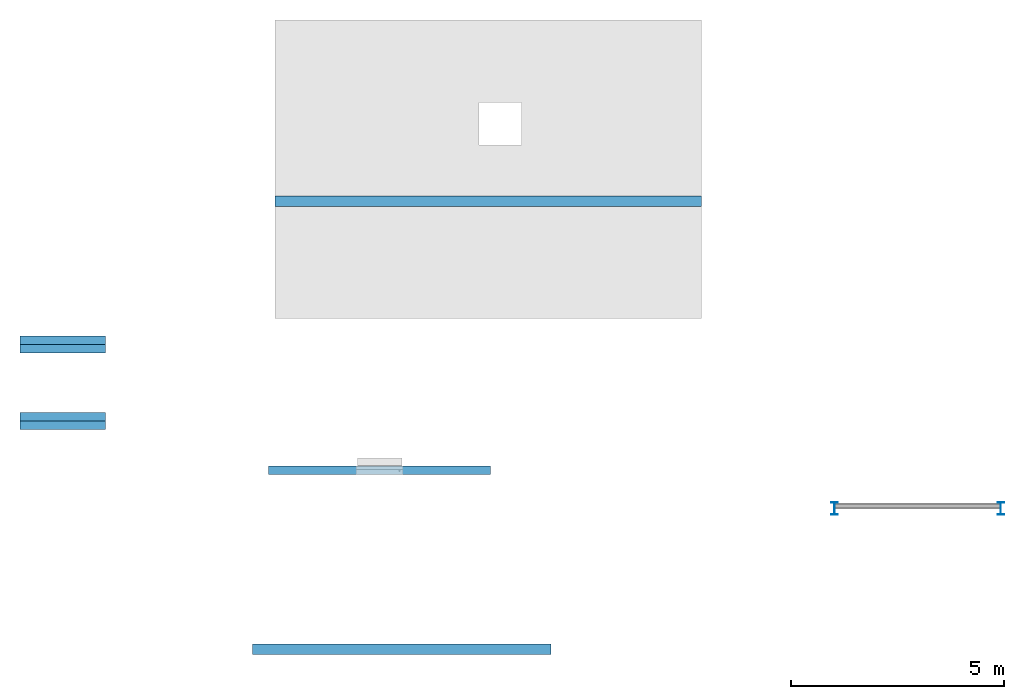
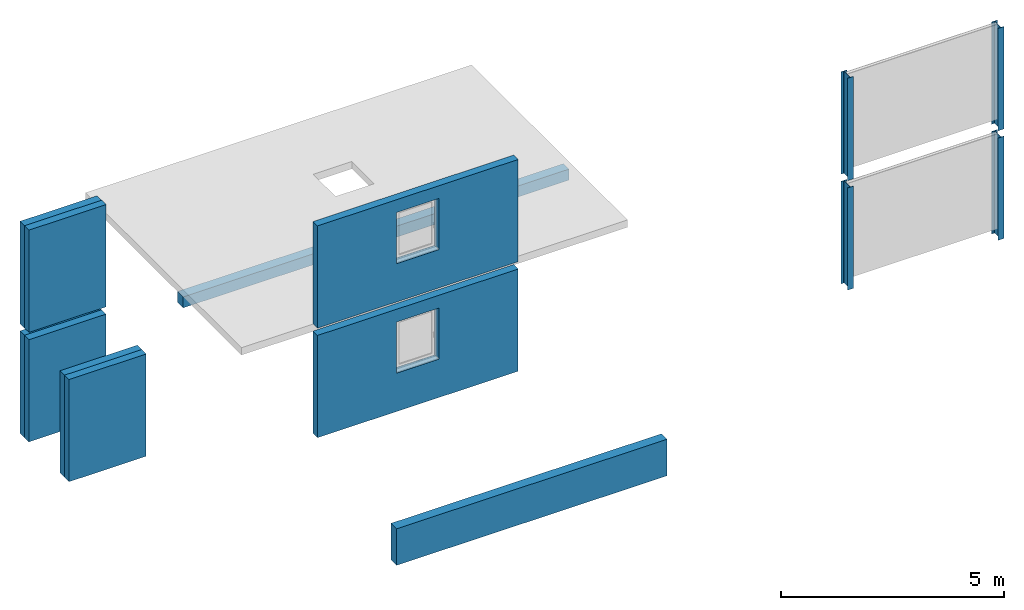
# Not in any storey, part 1 of 3: 8 building element parts, 4 columns, 1 beam, 1 footing, 5 elements without a shape of their own.
"""IFC4 model written with IfcOpenShell, lengths in metres."""

from ifc_helpers import new_model, entity, si_unit, converted_unit, derived_unit, direction, frame, origin, place, context, subcontext, project, spatial, line, arc, indexed_curve, outline, extrude, source, transform, mapped, material, type_object, type_shapes, element, aggregate, save


model = new_model("IFC4")

# Units and contexts
model_context = context("Model", 3, precision=1e-05, world=origin(), true_north=direction((6.123031769111886e-17, 1.0)))
body_context = subcontext(model_context, "Body", "Model", "MODEL_VIEW")
ifc_project = project(units=[si_unit("LENGTHUNIT", "METRE"), si_unit("AREAUNIT", "SQUARE_METRE"), si_unit("VOLUMEUNIT", "CUBIC_METRE"), converted_unit("PLANEANGLEUNIT", "DEGREE", entity("IfcRatioMeasure", 0.017453292519943278), si_unit("PLANEANGLEUNIT", "RADIAN"), dimensions=[0, 0, 0, 0, 0, 0, 0]), si_unit("MASSUNIT", "GRAM", prefix="KILO"), derived_unit("MASSDENSITYUNIT", [(si_unit("MASSUNIT", "GRAM", prefix="KILO"), 1), (si_unit("LENGTHUNIT", "METRE"), -3)]), derived_unit("IONCONCENTRATIONUNIT", [(si_unit("MASSUNIT", "GRAM", prefix="KILO"), 1), (si_unit("LENGTHUNIT", "METRE"), -3)]), derived_unit("MOMENTOFINERTIAUNIT", [(si_unit("LENGTHUNIT", "METRE"), 4)]), si_unit("TIMEUNIT", "SECOND"), si_unit("FREQUENCYUNIT", "HERTZ"), si_unit("THERMODYNAMICTEMPERATUREUNIT", "DEGREE_CELSIUS"), derived_unit("THERMALTRANSMITTANCEUNIT", [(si_unit("MASSUNIT", "GRAM", prefix="KILO"), 1), (si_unit("THERMODYNAMICTEMPERATUREUNIT", "KELVIN"), -1), (si_unit("TIMEUNIT", "SECOND"), -3)]), derived_unit("THERMALCONDUCTANCEUNIT", [(si_unit("MASSUNIT", "GRAM", prefix="KILO"), 1), (si_unit("THERMODYNAMICTEMPERATUREUNIT", "KELVIN"), -1), (si_unit("TIMEUNIT", "SECOND"), -3), (si_unit("LENGTHUNIT", "METRE"), 1)]), derived_unit("VOLUMETRICFLOWRATEUNIT", [(si_unit("LENGTHUNIT", "METRE"), 3), (si_unit("TIMEUNIT", "SECOND"), -1)]), derived_unit("MASSFLOWRATEUNIT", [(si_unit("MASSUNIT", "GRAM", prefix="KILO"), 1), (si_unit("TIMEUNIT", "SECOND"), -1)]), derived_unit("ROTATIONALFREQUENCYUNIT", [(si_unit("TIMEUNIT", "SECOND"), -1)]), si_unit("ELECTRICCURRENTUNIT", "AMPERE"), si_unit("ELECTRICVOLTAGEUNIT", "VOLT"), si_unit("POWERUNIT", "WATT"), si_unit("FORCEUNIT", "NEWTON", prefix="KILO"), si_unit("ILLUMINANCEUNIT", "LUX"), si_unit("LUMINOUSFLUXUNIT", "LUMEN"), si_unit("LUMINOUSINTENSITYUNIT", "CANDELA"), derived_unit("USERDEFINED", [(si_unit("MASSUNIT", "GRAM", prefix="KILO"), -1), (si_unit("LENGTHUNIT", "METRE"), -2), (si_unit("TIMEUNIT", "SECOND"), 3), (si_unit("LUMINOUSFLUXUNIT", "LUMEN"), 1)]), derived_unit("USERDEFINED", [(si_unit("MASSUNIT", "GRAM", prefix="KILO"), 1), (si_unit("TIMEUNIT", "SECOND"), -3), (si_unit("LENGTHUNIT", "METRE"), 3), (si_unit("ELECTRICCURRENTUNIT", "AMPERE"), -2)]), derived_unit("SOUNDPOWERUNIT", [(si_unit("MASSUNIT", "GRAM", prefix="KILO"), 1), (si_unit("TIMEUNIT", "SECOND"), -3), (si_unit("LENGTHUNIT", "METRE"), 2)]), derived_unit("SOUNDPRESSUREUNIT", [(si_unit("MASSUNIT", "GRAM", prefix="KILO"), 1), (si_unit("LENGTHUNIT", "METRE"), -1), (si_unit("TIMEUNIT", "SECOND"), -2)]), derived_unit("LINEARVELOCITYUNIT", [(si_unit("LENGTHUNIT", "METRE"), 1), (si_unit("TIMEUNIT", "SECOND"), -1)]), si_unit("PRESSUREUNIT", "PASCAL"), derived_unit("USERDEFINED", [(si_unit("MASSUNIT", "GRAM", prefix="KILO"), 1), (si_unit("LENGTHUNIT", "METRE"), -2), (si_unit("TIMEUNIT", "SECOND"), -2)]), derived_unit("LINEARFORCEUNIT", [(si_unit("MASSUNIT", "GRAM", prefix="KILO"), 1), (si_unit("TIMEUNIT", "SECOND"), -2)]), derived_unit("PLANARFORCEUNIT", [(si_unit("MASSUNIT", "GRAM", prefix="KILO"), 1), (si_unit("LENGTHUNIT", "METRE"), -1), (si_unit("TIMEUNIT", "SECOND"), -2)]), derived_unit("SPECIFICHEATCAPACITYUNIT", [(si_unit("THERMODYNAMICTEMPERATUREUNIT", "KELVIN"), -1), (si_unit("LENGTHUNIT", "METRE"), 2), (si_unit("TIMEUNIT", "SECOND"), -2)]), derived_unit("HEATINGVALUEUNIT", [(si_unit("LENGTHUNIT", "METRE"), 2), (si_unit("TIMEUNIT", "SECOND"), -2)]), derived_unit("VAPORPERMEABILITYUNIT", [(si_unit("LENGTHUNIT", "METRE"), -1), (si_unit("TIMEUNIT", "SECOND"), 1)]), derived_unit("DYNAMICVISCOSITYUNIT", [(si_unit("MASSUNIT", "GRAM", prefix="KILO"), 1), (si_unit("TIMEUNIT", "SECOND"), -1), (si_unit("LENGTHUNIT", "METRE"), -1)]), derived_unit("THERMALEXPANSIONCOEFFICIENTUNIT", [(si_unit("THERMODYNAMICTEMPERATUREUNIT", "KELVIN"), -1)]), derived_unit("MODULUSOFELASTICITYUNIT", [(si_unit("MASSUNIT", "GRAM", prefix="KILO"), 1), (si_unit("LENGTHUNIT", "METRE"), -1), (si_unit("TIMEUNIT", "SECOND"), -2)]), derived_unit("ISOTHERMALMOISTURECAPACITYUNIT", [(si_unit("LENGTHUNIT", "METRE"), 3), (si_unit("MASSUNIT", "GRAM", prefix="KILO"), -1)]), derived_unit("MOISTUREDIFFUSIVITYUNIT", [(si_unit("TIMEUNIT", "SECOND"), -1), (si_unit("LENGTHUNIT", "METRE"), 2)])], contexts=[model_context])

# Site
site_placement = place(None, origin())
site = spatial("IfcSite", under=ifc_project, at=site_placement, CompositionType="ELEMENT")

# Footing
ifc_material_1 = material(Name="Ortbeton - bewehrt Verputzt", Category="Generisch")
footing_type = type_object("IfcFootingType", PredefinedType="STRIP_FOOTING", material=ifc_material_1)
shared_shape_1 = source(origin(), body_context, "Body", "SweptSolid", [
    extrude(outline(indexed_curve([(-3.5000000000000004, -0.12500000000000167), (3.5000000000000004, -0.12500000000000167), (3.5000000000000004, 0.12500000000000167), (-3.5000000000000004, 0.12500000000000167), (-3.5000000000000004, -0.12500000000000167)], self_intersect=False)), frame((0.0, 0.0, -0.5000000000000053), z_axis=(0.0, 0.0, 1.0), x_axis=(-1.0, 0.0, 0.0)), (0.0, 0.0, 1.0), 0.9999999999999997),
])
type_shapes(footing_type, [shared_shape_1])
footing_placement = place(site_placement, frame((15.65412915446883, 6.304003160627488, -0.4999999999999961)))
element("IfcFooting", 1, at=footing_placement, inside=site, type_object=footing_type, material=ifc_material_1, PredefinedType="STRIP_FOOTING", context=body_context, shape_type="MappedRepresentation", body=[
    mapped(shared_shape_1, transform((0.0, 0.0, 0.0), scale=1.0)),
])

# Columns
ifc_material_2 = material(Name="Metall - Baustahl S235", Category="Metall")
column_type_1 = type_object("IfcColumnType", PredefinedType="COLUMN", material=ifc_material_2)
shared_shape_2 = source(origin(), body_context, "Body", "SweptSolid", [
    extrude(outline(indexed_curve([(0.13929999999999998, -0.07499999999999998), (0.14999999999999997, -0.07499999999999998), (0.14999999999999997, 0.07500000000000001), (0.13929999999999998, 0.07500000000000001), (0.13929999999999998, 0.018550000000000094), (0.13490660171779825, 0.007943398282201836), (0.12430000000000004, 0.003550000000000002), (-0.12429999999999991, 0.0035500000000000063), (-0.13490660171779817, 0.007943398282201732), (-0.1393, 0.018550000000000025), (-0.1393, 0.07500000000000001), (-0.15000000000000002, 0.07500000000000001), (-0.15000000000000002, -0.07499999999999998), (-0.1393, -0.07499999999999998), (-0.1393, -0.018550000000000188), (-0.13490660171779834, -0.007943398282201903), (-0.12430000000000002, -0.0035499999999999915), (0.1242999999999998, -0.0035500000000000145), (0.13490660171779806, -0.007943398282201693), (0.13929999999999998, -0.018549999999999966)], segments=[line(1, 2, 3, 4, 5), arc(5, 6, 7), line(7, 8), arc(8, 9, 10), line(10, 11, 12, 13, 14, 15), arc(15, 16, 17), line(17, 18), arc(18, 19, 20), line(20, 1)], self_intersect=False)), frame((0.0, 0.0, -0.2), z_axis=(0.0, 0.0, 1.0), x_axis=(0.0, -1.0, 0.0)), (0.0, 0.0, 1.0), 2.8000000000000003),
])
type_shapes(column_type_1, [shared_shape_2])
for number, where in (
    (2, (25.80000000000002, 9.600203538913608, 0.0)),
    (3, (29.700000000000017, 9.600203538913608, 0.0)),
):
    element("IfcColumn", number, at=place(site_placement, frame(where)), inside=site, type_object=column_type_1, material=ifc_material_2, PredefinedType="COLUMN", context=body_context, shape_type="MappedRepresentation", body=[
        mapped(shared_shape_2, transform((0.0, 0.0, 0.0), scale=1.0)),
    ])
column_type_2 = type_object("IfcColumnType", PredefinedType="COLUMN", material=ifc_material_2)
shared_shape_3 = source(origin(), body_context, "Body", "SweptSolid", [
    extrude(outline(indexed_curve([(0.13929999999999998, -0.07499999999999998), (0.14999999999999997, -0.07499999999999998), (0.14999999999999997, 0.07500000000000001), (0.13929999999999998, 0.07500000000000001), (0.13929999999999998, 0.018550000000000094), (0.13490660171779825, 0.007943398282201836), (0.12430000000000004, 0.003550000000000002), (-0.12429999999999991, 0.0035500000000000063), (-0.13490660171779817, 0.007943398282201732), (-0.1393, 0.018550000000000025), (-0.1393, 0.07500000000000001), (-0.15000000000000002, 0.07500000000000001), (-0.15000000000000002, -0.07499999999999998), (-0.1393, -0.07499999999999998), (-0.1393, -0.018550000000000188), (-0.13490660171779834, -0.007943398282201903), (-0.12430000000000002, -0.0035499999999999915), (0.1242999999999998, -0.0035500000000000145), (0.13490660171779806, -0.007943398282201693), (0.13929999999999998, -0.018549999999999966)], segments=[line(1, 2, 3, 4, 5), arc(5, 6, 7), line(7, 8), arc(8, 9, 10), line(10, 11, 12, 13, 14, 15), arc(15, 16, 17), line(17, 18), arc(18, 19, 20), line(20, 1)], self_intersect=False)), frame((0.0, 0.0, 2.8000000000000003), z_axis=(0.0, 0.0, 1.0), x_axis=(0.0, -1.0, 0.0)), (0.0, 0.0, 1.0), 2.8000000000000003),
])
type_shapes(column_type_2, [shared_shape_3])
for number, where in (
    (4, (25.80000000000002, 9.600203538913608, 0.0)),
    (5, (29.700000000000017, 9.600203538913608, 0.0)),
):
    element("IfcColumn", number, at=place(site_placement, frame(where)), inside=site, type_object=column_type_2, material=ifc_material_2, PredefinedType="COLUMN", context=body_context, shape_type="MappedRepresentation", body=[
        mapped(shared_shape_3, transform((0.0, 0.0, 0.0), scale=1.0)),
    ])

# Beam
beam_type_1 = type_object("IfcBeamType", PredefinedType="BEAM", material=ifc_material_1)
shared_shape_4 = source(origin(), body_context, "Body", "SweptSolid", [
    extrude(outline(indexed_curve([(-0.15000000000001437, -0.12499999999999432), (0.14999999999998728, -0.1250000000000268), (0.15000000000001437, 0.124999999999977), (-0.14999999999998728, 0.12500000000004413), (-0.15000000000001437, -0.12499999999999432)], self_intersect=False)), frame((12.680194081769871, 16.800203538913593, -0.35000000000000087), z_axis=(1.0, 0.0, 0.0), x_axis=(0.0, 0.0, -1.0)), (0.0, 0.0, 1.0), 10.0),
])
type_shapes(beam_type_1, [shared_shape_4])
beam_1_placement = place(site_placement, origin())
element("IfcBeam", 6, at=beam_1_placement, inside=site, type_object=beam_type_1, material=ifc_material_1, PredefinedType="BEAM", context=body_context, shape_type="MappedRepresentation", body=[
    mapped(shared_shape_4, transform((0.0, 0.0, 0.0), scale=1.0)),
])

# Beam, building element part
beam_type_2 = type_object("IfcBeamType", Name="Wand", PredefinedType="NOTDEFINED")
beam_2_placement = place(site_placement, frame((12.538526378542784, 10.500203538913624, 0.0)))
beam_2 = element("IfcBeam", 7, at=beam_2_placement, inside=site, type_object=beam_type_2, Name="Wand", ObjectType="Wand", PredefinedType="NOTDEFINED")
building_element_part_1_placement = place(beam_2_placement, origin())
building_element_part_1 = element("IfcBuildingElementPart", 8, at=building_element_part_1_placement, material=ifc_material_1, Name="Ortbeton - bewehrt Verputzt", context=body_context, shape_type="SweptSolid", body=[
    extrude(outline(indexed_curve([(-1.4000000000000001, -2.6), (1.4000000000000001, -2.6), (1.4000000000000001, 2.6), (-1.4000000000000001, 2.6), (-1.4000000000000001, -2.6)], self_intersect=False), holes=[indexed_curve([(1.0499999999999883, -0.5500000000000006), (-0.35000000000000014, -0.5500000000000006), (-0.35000000000000003, 0.5499999999999984), (1.0499999999999883, 0.5499999999999984), (1.0499999999999883, -0.5500000000000006)], self_intersect=False)]), frame((2.6, -0.09999999999999892, 1.2000000000000002), z_axis=(0.0, 1.0, 0.0), x_axis=(0.0, 0.0, 1.0)), (0.0, 0.0, 1.0), 0.2),
])
aggregate(beam_2, [building_element_part_1])

# Wall, building element parts
wall_type = type_object("IfcWallType", Name="Ziegel+WD 200+200", PredefinedType="STANDARD")
wall_1_placement = place(site_placement, frame((6.707929975013882, 13.44669280999048, 0.0)))
wall_1 = element("IfcWall", 9, at=wall_1_placement, inside=site, type_object=wall_type, Name="Ziegel+WD 200+200", ObjectType="Ziegel+WD 200+200", PredefinedType="NOTDEFINED")
ifc_material_3 = material(Name="Mauerwerk - Ziegel", Category="Generisch")
building_element_part_2_placement = place(wall_1_placement, origin())
building_element_part_2 = element("IfcBuildingElementPart", 10, at=building_element_part_2_placement, material=ifc_material_3, Name="Mauerwerk - Ziegel", context=body_context, shape_type="SweptSolid", body=[
    extrude(outline(indexed_curve([(-0.1, -1.0000000000000007), (0.1, -1.0000000000000007), (0.09999999999999568, 0.9999999999999996), (-0.10000000000000434, 0.9999999999999996), (-0.1, -1.0000000000000007)], self_intersect=False)), frame((1.0, -0.10000000000000325, 0.0), z_axis=(0.0, 0.0, 1.0), x_axis=(0.0, -1.0, 0.0)), (0.0, 0.0, 1.0), 2.8000000000000003),
])
ifc_material_4 = material(Category="Generisch")
building_element_part_3_placement = place(wall_1_placement, origin())
building_element_part_3 = element("IfcBuildingElementPart", 11, at=building_element_part_3_placement, material=ifc_material_4, context=body_context, shape_type="SweptSolid", body=[
    extrude(outline(indexed_curve([(-0.10000000000000109, -1.0), (0.09999999999999892, -1.0), (0.10000000000000542, 1.0), (-0.0999999999999946, 1.0), (-0.10000000000000109, -1.0)], self_intersect=False)), frame((1.0, 0.10000000000000109, 0.0), z_axis=(0.0, 0.0, 1.0), x_axis=(0.0, -1.0, 0.0)), (0.0, 0.0, 1.0), 2.8000000000000003),
])
aggregate(wall_1, [building_element_part_2, building_element_part_3])

wall_2_placement = place(site_placement, frame((6.707929975013879, 11.646692809990482, 0.0)))
wall_2 = element("IfcWall", 12, at=wall_2_placement, inside=site, type_object=wall_type, Name="Ziegel+WD 200+200", ObjectType="Ziegel+WD 200+200", PredefinedType="NOTDEFINED")
building_element_part_4_placement = place(wall_2_placement, origin())
building_element_part_4 = element("IfcBuildingElementPart", 13, at=building_element_part_4_placement, material=ifc_material_3, context=body_context, shape_type="SweptSolid", body=[
    extrude(outline(indexed_curve([(-0.10000000000000325, -1.0), (0.09999999999999676, -1.0), (0.10000000000000325, 1.0), (-0.09999999999999676, 1.0), (-0.10000000000000325, -1.0)], self_intersect=False)), frame((1.0, -0.10000000000000109, 0.0), z_axis=(0.0, 0.0, 1.0), x_axis=(0.0, -1.0, 0.0)), (0.0, 0.0, 1.0), 2.8000000000000003),
])
building_element_part_5_placement = place(wall_2_placement, origin())
building_element_part_5 = element("IfcBuildingElementPart", 14, at=building_element_part_5_placement, material=ifc_material_4, context=body_context, shape_type="SweptSolid", body=[
    extrude(outline(indexed_curve([(-0.1, -1.0000000000000007), (0.1, -1.0000000000000007), (0.09999999999999568, 0.9999999999999996), (-0.10000000000000434, 0.9999999999999996), (-0.1, -1.0000000000000007)], self_intersect=False)), frame((1.0, 0.09999999999999676, 0.0), z_axis=(0.0, 0.0, 1.0), x_axis=(0.0, -1.0, 0.0)), (0.0, 0.0, 1.0), 2.8000000000000003),
])
aggregate(wall_2, [building_element_part_4, building_element_part_5])

# Beam, building element part
beam_3_placement = place(site_placement, frame((12.538526378542784, 10.500203538913624, 0.0)))
beam_3 = element("IfcBeam", 15, at=beam_3_placement, inside=site, type_object=beam_type_2, Name="Wand", ObjectType="Wand", PredefinedType="NOTDEFINED")
building_element_part_6_placement = place(beam_3_placement, origin())
building_element_part_6 = element("IfcBuildingElementPart", 16, at=building_element_part_6_placement, material=ifc_material_1, Name="Ortbeton - bewehrt Verputzt", context=body_context, shape_type="SweptSolid", body=[
    extrude(outline(indexed_curve([(-1.4000000000000001, -2.6), (1.4000000000000001, -2.6), (1.4000000000000001, 2.6), (-1.4000000000000001, 2.6), (-1.4000000000000001, -2.6)], self_intersect=False), holes=[indexed_curve([(1.0499999999999887, -0.5500000000000006), (-0.35000000000000003, -0.5500000000000006), (-0.35000000000000003, 0.5499999999999984), (1.0499999999999887, 0.5499999999999984), (1.0499999999999887, -0.5500000000000006)], self_intersect=False)]), frame((2.6, -0.09999999999999892, 4.2), z_axis=(0.0, 1.0, 0.0), x_axis=(0.0, 0.0, 1.0)), (0.0, 0.0, 1.0), 0.2),
])
aggregate(beam_3, [building_element_part_6])

# Wall, building element parts
wall_3_placement = place(site_placement, frame((6.707929975013882, 13.44669280999048, 0.0)))
wall_3 = element("IfcWall", 17, at=wall_3_placement, inside=site, type_object=wall_type, Name="Ziegel+WD 200+200", ObjectType="Ziegel+WD 200+200", PredefinedType="NOTDEFINED")
building_element_part_7_placement = place(wall_3_placement, origin())
building_element_part_7 = element("IfcBuildingElementPart", 18, at=building_element_part_7_placement, material=ifc_material_3, Name="Mauerwerk - Ziegel", context=body_context, shape_type="SweptSolid", body=[
    extrude(outline(indexed_curve([(-0.1, -1.0000000000000007), (0.1, -1.0000000000000007), (0.09999999999999568, 0.9999999999999996), (-0.10000000000000434, 0.9999999999999996), (-0.1, -1.0000000000000007)], self_intersect=False)), frame((1.0, -0.10000000000000325, 3.0), z_axis=(0.0, 0.0, 1.0), x_axis=(0.0, -1.0, 0.0)), (0.0, 0.0, 1.0), 2.8000000000000003),
])
building_element_part_8_placement = place(wall_3_placement, origin())
building_element_part_8 = element("IfcBuildingElementPart", 19, at=building_element_part_8_placement, material=ifc_material_4, context=body_context, shape_type="SweptSolid", body=[
    extrude(outline(indexed_curve([(-0.10000000000000109, -1.0), (0.09999999999999892, -1.0), (0.10000000000000542, 1.0), (-0.0999999999999946, 1.0), (-0.10000000000000109, -1.0)], self_intersect=False)), frame((1.0, 0.10000000000000109, 3.0), z_axis=(0.0, 0.0, 1.0), x_axis=(0.0, -1.0, 0.0)), (0.0, 0.0, 1.0), 2.8000000000000003),
])
aggregate(wall_3, [building_element_part_7, building_element_part_8])

save(model, "model.ifc")
